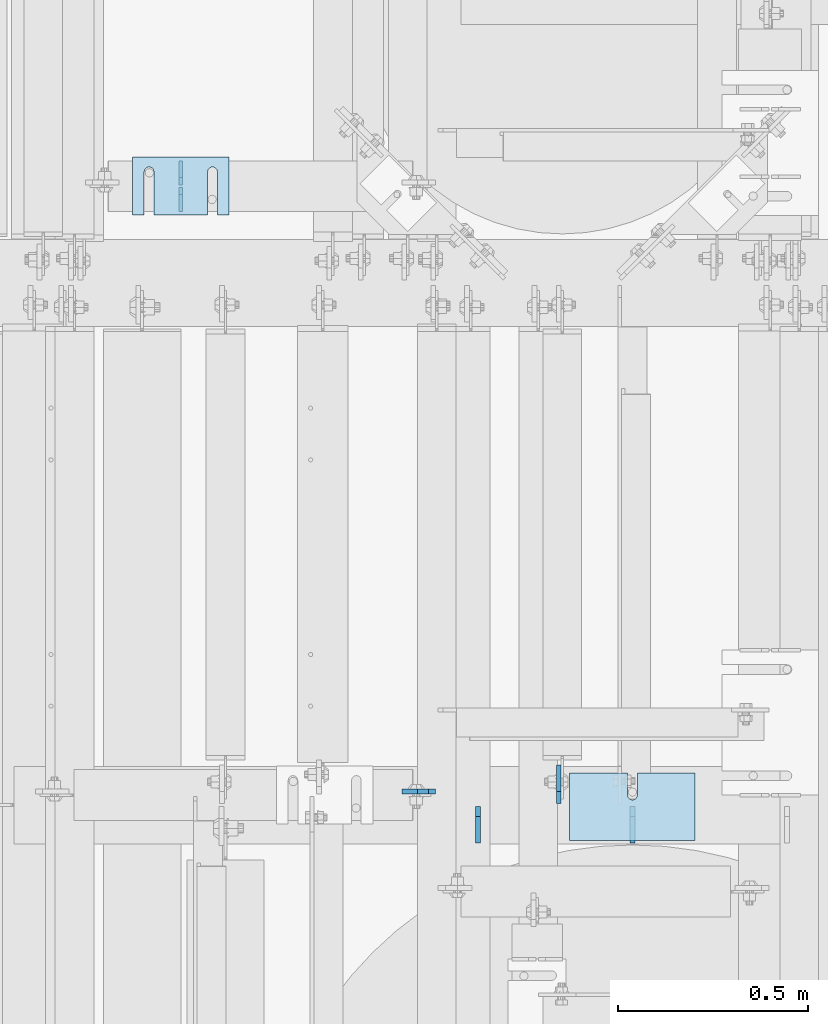
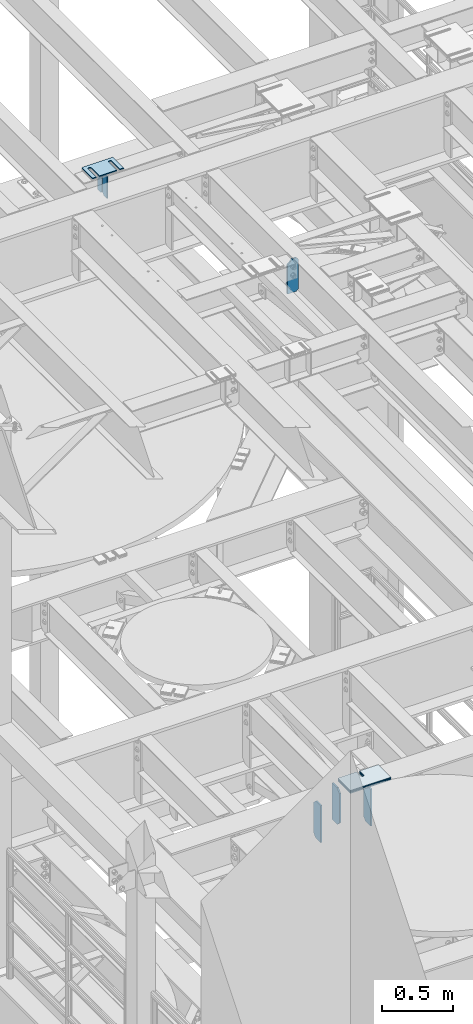
# One storey, part 1698 of 1876: 14 plates, 11 elements without a shape of their own.
"""IFC2X3 building model written with IfcOpenShell, lengths in millimetres."""

import ifcopenshell
import ifcopenshell.guid

model = None  # the IFC model being written
_history = None  # IfcOwnerHistory: only IFC2X3 demands one
_inside = {}  # id of a spatial element -> (the spatial element, [elements in it])
_under = {}  # id of a project, library or spatial element -> (it, [spatial elements below it])
_declared = {}  # id of a project -> (the project, [libraries it declares])
_typed = {}  # id of a type object -> (the type object, [elements of that type])
_made_of = {}  # id of a material, layer set ... -> (it, [elements and type objects made of it])


def new_model(schema):
    """Start an empty IFC model of exactly this schema.

    Asked for "IFC4X3", IfcOpenShell would pick the latest addendum, in which some entities
    have other attributes; the version numbers below select the first issue.
    IFC2X3 requires an IfcOwnerHistory on every rooted entity: one is made here for all.
    """
    global model, _history
    if schema == "IFC4X3":
        model = ifcopenshell.file(schema_version=(4, 3, 0, 0))
    else:
        model = ifcopenshell.file(schema=schema)
    _inside.clear()
    _under.clear()
    _declared.clear()
    _typed.clear()
    _made_of.clear()
    _history = None
    if model.schema == "IFC2X3":
        org = make("IfcOrganization", Name="unknown")
        user = make(
            "IfcPersonAndOrganization",
            ThePerson=make("IfcPerson", FamilyName="unknown"),
            TheOrganization=org,
        )
        app = make(
            "IfcApplication",
            ApplicationDeveloper=org,
            Version="unknown",
            ApplicationFullName="unknown",
            ApplicationIdentifier="unknown",
        )
        _history = make(
            "IfcOwnerHistory",
            OwningUser=user,
            OwningApplication=app,
            ChangeAction="ADDED",
            CreationDate=0,
        )
    return model


def make(cls, **values):
    """One entity of the class cls with the attributes given. An attribute that is None is left unset."""
    return model.create_entity(
        cls, **{name: value for name, value in values.items() if value is not None}
    )


def rooted(cls, **values):
    """An entity with a GlobalId (a new one), such as an element, a storey or a relation."""
    return make(cls, GlobalId=ifcopenshell.guid.new(), OwnerHistory=_history, **values)


def si_unit(unit_type, name, prefix=None):
    """IfcSIUnit, for example si_unit("LENGTHUNIT", "METRE", prefix="MILLI")."""
    return make("IfcSIUnit", UnitType=unit_type, Prefix=prefix, Name=name)


def assignment(units):
    """IfcUnitAssignment: the units of a project."""
    return None if units is None else make("IfcUnitAssignment", Units=units)


def point(xyz):
    """IfcCartesianPoint."""
    return None if xyz is None else make("IfcCartesianPoint", Coordinates=xyz)


def direction(xyz):
    """IfcDirection."""
    return None if xyz is None else make("IfcDirection", DirectionRatios=xyz)


def frame(location, z_axis=None, x_axis=None):
    """IfcAxis2Placement3D, a coordinate frame: its origin and axes. An axis left out is left unset."""
    return make(
        "IfcAxis2Placement3D",
        Location=point(location),
        Axis=direction(z_axis),
        RefDirection=direction(x_axis),
    )


def origin_with_axes():
    """The frame at (0, 0, 0) with the z axis (0, 0, 1) and the x axis (1, 0, 0) written out."""
    return frame((0.0, 0.0, 0.0), z_axis=(0.0, 0.0, 1.0), x_axis=(1.0, 0.0, 0.0))


def place(relative_to, where):
    """IfcLocalPlacement: puts the frame where relative to a parent placement (None: the world)."""
    return make(
        "IfcLocalPlacement", PlacementRelTo=relative_to, RelativePlacement=where
    )


def context(
    kind, dimensions, precision=None, world=None, true_north=None, identifier=None
):
    """IfcGeometricRepresentationContext, for example the 3D "Model" context."""
    return make(
        "IfcGeometricRepresentationContext",
        ContextIdentifier=identifier,
        ContextType=kind,
        CoordinateSpaceDimension=dimensions,
        Precision=precision,
        WorldCoordinateSystem=world,
        TrueNorth=true_north,
    )


def subcontext(parent, identifier, kind, view, scale=None):
    """IfcGeometricRepresentationSubContext, for example "Body" below "Model"."""
    return make(
        "IfcGeometricRepresentationSubContext",
        ContextIdentifier=identifier,
        ContextType=kind,
        ParentContext=parent,
        TargetScale=scale,
        TargetView=view,
    )


def project(units=None, contexts=None):
    """IfcProject with its units and contexts."""
    return rooted(
        "IfcProject",
        Name="project",
        RepresentationContexts=contexts,
        UnitsInContext=assignment(units),
    )


def spatial(cls, under=None, at=None, **own):
    """A site, building, storey or space (cls), placed at a placement, below another one or the project."""
    s = rooted(cls, ObjectPlacement=at, **own)
    if under is not None:
        _under.setdefault(under.id(), (under, []))[1].append(s)
    return s


def faces_of(points, faces, orient=None, outer=None):
    """IfcFace entities. A face is a list of loops; a loop is a list of indices into points, from 0.

    orient and outer hold one flag for each loop. By default every Orientation is true, the
    first loop of a face is its IfcFaceOuterBound and the others are IfcFaceBound.
    """
    made = []
    for i, loops in enumerate(faces):
        bounds = []
        for j, loop in enumerate(loops):
            is_outer = j == 0 if outer is None else outer[i][j]
            bounds.append(
                make(
                    "IfcFaceOuterBound" if is_outer else "IfcFaceBound",
                    Bound=make("IfcPolyLoop", Polygon=[points[k] for k in loop]),
                    Orientation=True if orient is None else orient[i][j],
                )
            )
        made.append(make("IfcFace", Bounds=bounds))
    return made


def faceted_brep(points, faces, orient=None, outer=None, voids=None):
    """IfcFacetedBrep: a solid bounded by flat faces; with voids (closed shells), ...WithVoids."""
    shared = [point(p) for p in points]
    hull = make("IfcClosedShell", CfsFaces=faces_of(shared, faces, orient, outer))
    if voids is None:
        return make("IfcFacetedBrep", Outer=hull)
    return make(
        "IfcFacetedBrepWithVoids",
        Outer=hull,
        Voids=[
            make(cls, CfsFaces=faces_of(shared, fs, o, b)) for cls, fs, o, b in voids
        ],
    )


def shape(context_of_items, identifier, shape_type, items):
    """IfcShapeRepresentation: the items that make up one representation, for example the "Body"."""
    return make(
        "IfcShapeRepresentation",
        ContextOfItems=context_of_items,
        RepresentationIdentifier=identifier,
        RepresentationType=shape_type,
        Items=items,
    )


def material(Name=None, Category=None):
    """IfcMaterial."""
    return make("IfcMaterial", Name=Name, Category=Category)


def made_of(thing, what):
    """Note that an element or type object is made of a material, layer set ...; save() writes the relation."""
    if what is not None:
        _made_of.setdefault(what.id(), (what, []))[1].append(thing)
    return thing


def type_object(cls, material=None, **own):
    """A type object (cls), such as IfcWallType, which elements share."""
    return made_of(rooted(cls, **own), material)


def element(
    cls,
    number,
    at=None,
    inside=None,
    cuts=None,
    type_object=None,
    material=None,
    context=None,
    identifier="Body",
    shape_type=None,
    held_by="IfcProductDefinitionShape",
    body=None,
    shapes=None,
    **own,
):
    """One element of the class cls, such as IfcWall. Its Tag is "e" and its number.

    at: its placement. inside: the storey or other place that contains it. cuts: it is an
    opening in that element (IfcRelVoidsElement). A single representation is given by context,
    identifier, shape_type and body (its items); several are given by shapes. held_by: the class
    of the entity that holds the representations. save() writes the other relations.
    """
    e = rooted(cls, Tag="e%d" % number, ObjectPlacement=at, **own)
    if body is not None:
        shapes = [shape(context, identifier, shape_type, body)]
    if shapes is not None:
        e.Representation = make(held_by, Representations=shapes)
    if inside is not None:
        _inside.setdefault(inside.id(), (inside, []))[1].append(e)
    if cuts is not None:
        rooted(
            "IfcRelVoidsElement", RelatingBuildingElement=cuts, RelatedOpeningElement=e
        )
    if type_object is not None:
        _typed.setdefault(type_object.id(), (type_object, []))[1].append(e)
    return made_of(e, material)


def aggregate(whole, parts):
    """IfcRelAggregates: a whole, such as a stair, and the parts it consists of."""
    return rooted("IfcRelAggregates", RelatingObject=whole, RelatedObjects=parts)


def save(model, path):
    """Write the relations noted so far, then the file.

    IfcRelAggregates (storeys below a building ...), IfcRelContainedInSpatialStructure (elements
    in a storey), IfcRelDefinesByType, IfcRelAssociatesMaterial and IfcRelDeclares: one each for
    every whole, place, type object, material and project.
    """
    for whole, parts in _under.values():
        aggregate(whole, parts)
    for where, things in _inside.values():
        rooted(
            "IfcRelContainedInSpatialStructure",
            RelatedElements=things,
            RelatingStructure=where,
        )
    for kind, things in _typed.values():
        rooted("IfcRelDefinesByType", RelatedObjects=things, RelatingType=kind)
    for what, things in _made_of.values():
        rooted("IfcRelAssociatesMaterial", RelatedObjects=things, RelatingMaterial=what)
    for by, libraries in _declared.values():
        rooted("IfcRelDeclares", RelatingContext=by, RelatedDefinitions=libraries)
    model.write(path)


model = new_model("IFC2X3")

# Units and contexts
model_context = context("Model", 3, precision=1e-05, world=origin_with_axes())
body_context = subcontext(model_context, "Body", "Model", "MODEL_VIEW")
ifc_project = project(units=[si_unit("LENGTHUNIT", "METRE", prefix="MILLI"), si_unit("AREAUNIT", "SQUARE_METRE"), si_unit("VOLUMEUNIT", "CUBIC_METRE"), si_unit("MASSUNIT", "GRAM", prefix="KILO"), si_unit("TIMEUNIT", "SECOND"), si_unit("PLANEANGLEUNIT", "RADIAN"), si_unit("SOLIDANGLEUNIT", "STERADIAN"), si_unit("THERMODYNAMICTEMPERATUREUNIT", "DEGREE_CELSIUS"), si_unit("LUMINOUSINTENSITYUNIT", "LUMEN")], contexts=[model_context])

# Site, building, storey
site_placement = place(None, origin_with_axes())
site = spatial("IfcSite", under=ifc_project, at=site_placement, CompositionType="ELEMENT")
building_placement = place(site_placement, origin_with_axes())
building = spatial("IfcBuilding", under=site, at=building_placement, Name="Undefined", CompositionType="ELEMENT")
storey_placement = place(building_placement, origin_with_axes())
storey = spatial("IfcBuildingStorey", under=building, at=storey_placement, Name="Undefined", CompositionType="ELEMENT", Elevation=0.0)

# Assembly, plates
assembly_1_placement = place(storey_placement, origin_with_axes())
assembly_1 = element("IfcElementAssembly", 1, at=assembly_1_placement, inside=storey, Name="BEAM", AssemblyPlace="NOTDEFINED", PredefinedType="RIGID_FRAME")
ifc_material = material(Name="STEEL/A36")
plate_type_1 = type_object("IfcPlateType", PredefinedType="NOTDEFINED")
plate_1_placement = place(assembly_1_placement, frame((2184.3990270089, 7807.49544067383, 17784.7625), z_axis=(0.0, 0.0, 1.0), x_axis=(0.0, 1.0, 0.0)))
plate_1 = element("IfcPlate", 2, at=plate_1_placement, type_object=plate_type_1, material=ifc_material, Name="PLATE", context=body_context, shape_type="Brep", body=[
    faceted_brep([(0.0, -4.76249999999982, 0.0), (0.0, -4.76249999999982, 190.5), (0.0, 4.76249999999982, 190.5), (0.0, 4.76249999999982, 0.0), (44.4500007629395, -4.76249999999982, 190.5), (44.4500007629395, 4.76249999999982, 190.5), (63.5, -4.76249999999982, 171.450000762939), (63.5, 4.76249999999982, 171.450000762939), (63.5, -4.76249999999982, 19.0499992370605), (63.5, 4.76249999999982, 19.0499992370605), (44.4500007629395, -4.76249999999982, 0.0), (44.4500007629395, 4.76249999999982, 0.0)], [[[0, 1, 2, 3]], [[1, 4, 5, 2]], [[4, 6, 7, 5]], [[6, 8, 9, 7]], [[8, 10, 11, 9]], [[10, 0, 3, 11]], [[5, 7, 9, 11, 3, 2]], [[10, 8, 6, 4, 1, 0]]]),
])
plate_2_placement = place(assembly_1_placement, frame((2184.3990270089, 7877.34544067383, 17784.7625), z_axis=(0.0, 0.0, 1.0), x_axis=(0.0, 1.0, 0.0)))
plate_2 = element("IfcPlate", 3, at=plate_2_placement, type_object=plate_type_1, material=ifc_material, Name="PLATE", context=body_context, shape_type="Brep", body=[
    faceted_brep([(0.0, -4.76249999999982, 19.0499992370605), (0.0, -4.76249999999982, 171.450000762939), (0.0, 4.76249999999982, 171.450000762939), (0.0, 4.76249999999982, 19.0499992370605), (19.0499992370605, -4.76249999999982, 190.5), (19.0499992370605, 4.76249999999982, 190.5), (63.5, -4.76249999999982, 190.5), (63.5, 4.76249999999982, 190.5), (63.5, -4.76249999999982, 0.0), (63.5, 4.76249999999982, 0.0), (19.0499992370605, -4.76249999999982, 0.0), (19.0499992370605, 4.76249999999982, 0.0)], [[[0, 1, 2, 3]], [[1, 4, 5, 2]], [[4, 6, 7, 5]], [[6, 8, 9, 7]], [[8, 10, 11, 9]], [[10, 0, 3, 11]], [[5, 7, 9, 11, 3, 2]], [[10, 8, 6, 4, 1, 0]]]),
])
aggregate(assembly_1, [plate_1, plate_2])

# Assembly, plate
assembly_2_placement = place(storey_placement, origin_with_axes())
assembly_2 = element("IfcElementAssembly", 4, at=assembly_2_placement, inside=storey, Name="BEAM", AssemblyPlace="NOTDEFINED", PredefinedType="RIGID_FRAME")
plate_type_2 = type_object("IfcPlateType", PredefinedType="NOTDEFINED")
plate_3_placement = place(assembly_2_placement, frame((2854.325, 6282.7016907692, 17686.3375), z_axis=(0.0, 0.0, 1.0), x_axis=(-1.0, 0.0, 0.0)))
plate_3 = element("IfcPlate", 5, at=plate_3_placement, type_object=plate_type_2, material=ifc_material, Name="PLATE", context=body_context, shape_type="Brep", body=[
    faceted_brep([(0.0, -6.35000000000036, 271.462512969971), (19.0499992370605, -6.35000000000036, 290.512512207031), (19.0499992370605, 6.35000000000036, 290.512512207031), (0.0, 6.35000000000036, 271.462512969971), (0.0, -6.35000000000196, 19.0499992370605), (0.0, 6.35000000000105, 19.0499992370605), (19.0499992370642, -6.35000000000105, 0.0), (19.0499992370633, 6.35000000000105, 0.0), (88.9000015258789, -6.34999999999991, 0.0), (88.9000015258789, 6.34999999999991, 0.0), (88.9000015258789, -6.35000000000036, 249.323622869222), (47.7109133477634, -6.35000000000036, 290.512512207031), (47.6728323916896, 6.35000000000036, 290.512512207031), (88.9000015258789, 6.35000000000036, 249.285542096986)], [[[0, 1, 2, 3]], [[4, 0, 3, 5]], [[6, 4, 5, 7]], [[8, 6, 7, 9]], [[1, 0, 4, 6, 8, 10, 11]], [[2, 1, 11, 12]], [[9, 7, 5, 3, 2, 12, 13]], [[8, 9, 13, 10]], [[12, 11, 10, 13]]]),
])
aggregate(assembly_2, [plate_3])

# Assembly, plates
assembly_3_placement = place(storey_placement, origin_with_axes())
assembly_3 = element("IfcElementAssembly", 6, at=assembly_3_placement, inside=storey, Name="BEAM", AssemblyPlace="NOTDEFINED", PredefinedType="RIGID_FRAME")
plate_type_3 = type_object("IfcPlateType", PredefinedType="NOTDEFINED")
plate_4_placement = place(assembly_3_placement, frame((3371.85, 6147.59375, 12976.225), z_axis=(0.0, 0.0, 1.0), x_axis=(0.0, 1.0, 0.0)))
plate_4 = element("IfcPlate", 7, at=plate_4_placement, type_object=plate_type_3, material=ifc_material, Name="PLATE", context=body_context, shape_type="Brep", body=[
    faceted_brep([(0.0, -6.35000000000036, 0.0), (1.81898940354586e-12, -6.35000000000127, 317.5), (0.0, 6.35000000000036, 317.5), (0.0, 6.35000000000036, 0.0), (69.8500003814697, -6.34999999999991, 317.5), (69.8500003814697, 6.34999999999991, 317.5), (95.25, -6.34999999999991, 292.10000038147), (95.25, 6.34999999999991, 292.10000038147), (95.25, -6.34999999999991, 25.3999996185303), (95.25, 6.34999999999991, 25.3999996185303), (69.8500003814697, -6.34999999999991, 0.0), (69.8500003814697, 6.34999999999991, 0.0)], [[[0, 1, 2, 3]], [[1, 4, 5, 2]], [[4, 6, 7, 5]], [[6, 8, 9, 7]], [[8, 10, 11, 9]], [[10, 0, 3, 11]], [[5, 7, 9, 11, 3, 2]], [[10, 8, 6, 4, 1, 0]]]),
])
plate_5_placement = place(assembly_3_placement, frame((2965.4499996825, 6147.59375, 12976.225), z_axis=(0.0, 0.0, 1.0), x_axis=(0.0, 1.0, 0.0)))
plate_5 = element("IfcPlate", 8, at=plate_5_placement, type_object=plate_type_3, material=ifc_material, Name="PLATE", context=body_context, shape_type="Brep", body=[
    faceted_brep([(0.0, -6.35000000000036, 0.0), (1.81898940354586e-12, -6.35000000000127, 317.5), (0.0, 6.35000000000036, 317.5), (0.0, 6.35000000000036, 0.0), (69.8500003814697, -6.34999999999991, 317.5), (69.8500003814697, 6.34999999999991, 317.5), (95.25, -6.34999999999991, 292.10000038147), (95.25, 6.34999999999991, 292.10000038147), (95.25, -6.34999999999991, 25.3999996185303), (95.25, 6.34999999999991, 25.3999996185303), (69.8500003814697, -6.34999999999991, 0.0), (69.8500003814697, 6.34999999999991, 0.0)], [[[0, 1, 2, 3]], [[1, 4, 5, 2]], [[4, 6, 7, 5]], [[6, 8, 9, 7]], [[8, 10, 11, 9]], [[10, 0, 3, 11]], [[5, 7, 9, 11, 3, 2]], [[10, 8, 6, 4, 1, 0]]]),
])
plate_type_4 = type_object("IfcPlateType", PredefinedType="NOTDEFINED")
plate_6_placement = place(assembly_3_placement, frame((3178.17499990463, 6250.78125, 12977.8125), z_axis=(0.0, 0.0, 1.0), x_axis=(0.0, 1.0, 0.0)))
plate_6 = element("IfcPlate", 9, at=plate_6_placement, type_object=plate_type_4, material=ifc_material, Name="PLATE", context=body_context, shape_type="Brep", body=[
    faceted_brep([(0.0, -6.34999999999991, 31.75), (-1.81898940354586e-12, -6.34999999999991, 284.162506103516), (1.81898940354586e-12, 6.35000000000173, 284.162506103516), (0.0, 6.34999999999991, 31.75), (31.7499999999927, -6.34999999999991, 315.912506103516), (31.7499999999982, 6.35000000000309, 315.912506103516), (101.599998474121, -6.35000000000036, 315.912506103516), (101.599998474121, 6.35000000000036, 315.912506103516), (101.599998474121, -6.35000000000036, 0.0), (101.599998474121, 6.35000000000036, 0.0), (31.75, -6.34999999999991, 0.0), (31.75, 6.34999999999991, 0.0)], [[[0, 1, 2, 3]], [[1, 4, 5, 2]], [[4, 6, 7, 5]], [[6, 8, 9, 7]], [[8, 10, 11, 9]], [[10, 0, 3, 11]], [[5, 7, 9, 11, 3, 2]], [[10, 8, 6, 4, 1, 0]]]),
])
aggregate(assembly_3, [plate_4, plate_5, plate_6])

# Assembly, plate
assembly_4_placement = place(storey_placement, origin_with_axes())
assembly_4 = element("IfcElementAssembly", 10, at=assembly_4_placement, inside=storey, Name="SHIM PLATE", AssemblyPlace="NOTDEFINED", PredefinedType="RIGID_FRAME")
plate_type_5 = type_object("IfcPlateType", PredefinedType="NOTDEFINED")
plate_7_placement = place(assembly_4_placement, frame((2311.39928127175, 7950.43846988776, 18009.3925), z_axis=(0.0, -1.0, 0.0), x_axis=(-1.0, 0.0, 0.0)))
plate_7 = element("IfcPlate", 11, at=plate_7_placement, type_object=plate_type_5, material=ifc_material, Name="SHIM PLATE", context=body_context, shape_type="Brep", body=[
    faceted_brep([(30.8791924037423, -0.793499999999767, 152.398895263674), (30.8814140421409, -0.793499999999767, 38.0994505407325), (30.8814140421409, 0.793499999999767, 38.0994505407325), (30.8791924037423, 0.793499999999767, 152.398895263674), (32.5828868936751, -0.793499999999767, 31.7494480341243), (32.5828868936751, 0.793499999999767, 31.7494480341243), (37.2314075583954, -0.793499999999767, 27.1009216732054), (37.2314075583954, 0.793499999999767, 27.1009216732054), (43.5814079800521, -0.793499999999767, 25.3994410405157), (43.5814079800521, 0.793499999999767, 25.3994410405157), (49.9314097200559, -0.793499999999767, 27.1009167530574), (49.9314097200559, 0.793499999999767, 27.1009167530574), (54.5799339865616, -0.793499999999767, 31.7494395121785), (54.5799339865616, 0.793499999999767, 31.7494395121785), (56.2814117582284, -0.793499999999767, 38.0994407004391), (56.2814117582284, 0.793499999999767, 38.0994407004391), (56.2791901197206, -0.793499999999767, 152.398894414155), (56.2791901197206, 0.793499999999767, 152.398895263676), (9.09494701772928e-13, -0.793499999999767, 0.0), (1.98268335225293e-05, -0.793499999999767, 152.398895263672), (1.98268335225293e-05, 0.793499999999767, 152.398895263672), (9.09494701772928e-13, 0.793499999999767, 0.0), (253.999542236328, -0.793499999999767, 6.16182660451159e-11), (253.999542236328, 0.793499999999767, 6.16182660451159e-11), (253.999557495107, -0.793499999999767, 152.398895263688), (253.999557495107, 0.793499999999767, 152.398895263688), (223.116882380463, 0.793499999999767, 152.398895263686), (223.116882380463, -0.793499999999767, 152.398895415181), (223.119104018971, 0.793499999999767, 38.0994417014649), (223.119104018971, -0.793499999999767, 38.0994417014649), (221.417626247304, 0.793499999999767, 31.7494405132047), (221.417626247304, -0.793499999999767, 31.7494405132047), (216.769101980798, 0.793499999999767, 27.1009177540836), (216.769101980798, -0.793499999999767, 27.1009177540836), (210.419100240794, 0.793499999999767, 25.399442041542), (210.419100240794, -0.793499999999767, 25.399442041542), (204.069099819138, 0.793499999999767, 27.1009226742317), (204.069099819138, -0.793499999999767, 27.1009226742317), (199.420579154417, 0.793499999999767, 31.7494490351505), (199.420579154417, -0.793499999999767, 31.7494490351505), (197.719106302883, 0.793499999999767, 38.0994515417583), (197.719106302883, -0.793499999999767, 38.0994515417583), (197.716884664484, -0.793499999999767, 152.398895263684), (197.716884664484, 0.793499999999767, 152.398895263684)], [[[0, 1, 2, 3]], [[4, 5, 2, 1]], [[6, 7, 5, 4]], [[8, 9, 7, 6]], [[10, 11, 9, 8]], [[12, 13, 11, 10]], [[14, 15, 13, 12]], [[16, 17, 15, 14]], [[18, 19, 20, 21]], [[22, 18, 21, 23]], [[24, 22, 23, 25]], [[24, 25, 26, 27]], [[27, 26, 28, 29]], [[29, 28, 30, 31]], [[31, 30, 32, 33]], [[33, 32, 34, 35]], [[35, 34, 36, 37]], [[37, 36, 38, 39]], [[39, 38, 40, 41]], [[42, 41, 40, 43]], [[12, 10, 8, 6, 4, 1, 0, 19, 18, 22, 24, 27, 29, 31, 33, 35, 37, 39, 41, 42, 16, 14]], [[20, 19, 0, 3]], [[43, 40, 38, 36, 34, 32, 30, 28, 26, 25, 23, 21, 20, 3, 2, 5, 7, 9, 11, 13, 15, 17]], [[42, 43, 17, 16]]]),
])
aggregate(assembly_4, [plate_7])

assembly_5_placement = place(storey_placement, origin_with_axes())
assembly_5 = element("IfcElementAssembly", 12, at=assembly_5_placement, inside=storey, Name="SHIM PLATE", AssemblyPlace="NOTDEFINED", PredefinedType="RIGID_FRAME")
plate_type_6 = type_object("IfcPlateType", PredefinedType="NOTDEFINED")
plate_8_placement = place(assembly_5_placement, frame((2311.39928127175, 7950.43846988799, 18007.0115), z_axis=(0.0, -1.0, 0.0), x_axis=(-1.0, 0.0, 0.0)))
plate_8 = element("IfcPlate", 13, at=plate_8_placement, type_object=plate_type_6, material=ifc_material, Name="SHIM PLATE", context=body_context, shape_type="Brep", body=[
    faceted_brep([(30.8791924037423, -1.58750000000146, 152.398895263674), (30.8814140421409, -1.58750000000146, 38.0994505407325), (30.8814140421409, 1.58750000000146, 38.0994505407325), (30.8791924037423, 1.58750000000146, 152.398895263674), (32.5828868936751, -1.58750000000146, 31.7494480341243), (32.5828868936751, 1.58750000000146, 31.7494480341243), (37.2314075583954, -1.58750000000146, 27.1009216732054), (37.2314075583954, 1.58750000000146, 27.1009216732054), (43.5814079800521, -1.58750000000146, 25.3994410405157), (43.5814079800521, 1.58750000000146, 25.3994410405157), (49.9314097200559, -1.58750000000146, 27.1009167530574), (49.9314097200559, 1.58750000000146, 27.1009167530574), (54.5799339865616, -1.58750000000146, 31.7494395121785), (54.5799339865616, 1.58750000000146, 31.7494395121785), (56.2814117582284, -1.58750000000146, 38.0994407004391), (56.2814117582284, 1.58750000000146, 38.0994407004391), (56.2791901197206, -1.58750000000146, 152.398894414155), (56.2791901197206, 1.58750000000146, 152.398895263676), (9.09494701772928e-13, -1.58750000000146, 4.54747350886464e-13), (1.98264133359771e-05, -1.58750000000146, 152.398895263672), (1.98264133359771e-05, 1.58750000000146, 152.398895263672), (9.09494701772928e-13, 1.58750000000146, 4.54747350886464e-13), (253.999542236328, -1.58750000000146, 6.16182660451159e-11), (253.999542236328, 1.58750000000146, 6.16182660451159e-11), (253.999557495107, -1.58750000000146, 152.398895263688), (253.999557495107, 1.58750000000146, 152.398895263688), (223.116882380463, 1.58750000000146, 152.398895263686), (223.116882380463, -1.58750000000146, 152.398895415181), (223.119104018971, 1.58750000000146, 38.0994417014649), (223.119104018971, -1.58750000000146, 38.0994417014649), (221.417626247304, 1.58750000000146, 31.7494405132047), (221.417626247304, -1.58750000000146, 31.7494405132047), (216.769101980798, 1.58750000000146, 27.1009177540836), (216.769101980798, -1.58750000000146, 27.1009177540836), (210.419100240794, 1.58750000000146, 25.399442041542), (210.419100240794, -1.58750000000146, 25.399442041542), (204.069099819138, 1.58750000000146, 27.1009226742317), (204.069099819138, -1.58750000000146, 27.1009226742317), (199.420579154417, 1.58750000000146, 31.7494490351505), (199.420579154417, -1.58750000000146, 31.7494490351505), (197.719106302883, 1.58750000000146, 38.0994515417583), (197.719106302883, -1.58750000000146, 38.0994515417583), (197.716884664484, -1.58750000000146, 152.398895263684), (197.716884664484, 1.58750000000146, 152.398895263684)], [[[0, 1, 2, 3]], [[4, 5, 2, 1]], [[6, 7, 5, 4]], [[8, 9, 7, 6]], [[10, 11, 9, 8]], [[12, 13, 11, 10]], [[14, 15, 13, 12]], [[16, 17, 15, 14]], [[18, 19, 20, 21]], [[22, 18, 21, 23]], [[24, 22, 23, 25]], [[24, 25, 26, 27]], [[27, 26, 28, 29]], [[29, 28, 30, 31]], [[31, 30, 32, 33]], [[33, 32, 34, 35]], [[35, 34, 36, 37]], [[37, 36, 38, 39]], [[39, 38, 40, 41]], [[42, 41, 40, 43]], [[12, 10, 8, 6, 4, 1, 0, 19, 18, 22, 24, 27, 29, 31, 33, 35, 37, 39, 41, 42, 16, 14]], [[20, 19, 0, 3]], [[43, 40, 38, 36, 34, 32, 30, 28, 26, 25, 23, 21, 20, 3, 2, 5, 7, 9, 11, 13, 15, 17]], [[42, 43, 17, 16]]]),
])
aggregate(assembly_5, [plate_8])

assembly_6_placement = place(storey_placement, origin_with_axes())
assembly_6 = element("IfcElementAssembly", 14, at=assembly_6_placement, inside=storey, Name="SHIM PLATE", AssemblyPlace="NOTDEFINED", PredefinedType="RIGID_FRAME")
plate_9_placement = place(assembly_6_placement, frame((2311.39928127175, 7950.43846988822, 18003.8365), z_axis=(0.0, -1.0, 0.0), x_axis=(-1.0, 0.0, 0.0)))
plate_9 = element("IfcPlate", 15, at=plate_9_placement, type_object=plate_type_6, material=ifc_material, Name="SHIM PLATE", context=body_context, shape_type="Brep", body=[
    faceted_brep([(30.8791924037423, -1.58750000000146, 152.398895263674), (30.8814140421409, -1.58750000000146, 38.0994505407325), (30.8814140421409, 1.58750000000146, 38.0994505407325), (30.8791924037423, 1.58750000000146, 152.398895263674), (32.5828868936751, -1.58750000000146, 31.7494480341243), (32.5828868936751, 1.58750000000146, 31.7494480341243), (37.2314075583954, -1.58750000000146, 27.1009216732054), (37.2314075583954, 1.58750000000146, 27.1009216732054), (43.5814079800521, -1.58750000000146, 25.3994410405157), (43.5814079800521, 1.58750000000146, 25.3994410405157), (49.9314097200559, -1.58750000000146, 27.1009167530574), (49.9314097200559, 1.58750000000146, 27.1009167530574), (54.5799339865616, -1.58750000000146, 31.7494395121785), (54.5799339865616, 1.58750000000146, 31.7494395121785), (56.2814117582284, -1.58750000000146, 38.0994407004391), (56.2814117582284, 1.58750000000146, 38.0994407004391), (56.2791901197206, -1.58750000000146, 152.398894414155), (56.2791901197206, 1.58750000000146, 152.398895263676), (9.09494701772928e-13, -1.58750000000146, 4.54747350886464e-13), (1.98264133359771e-05, -1.58750000000146, 152.398895263672), (1.98264133359771e-05, 1.58750000000146, 152.398895263672), (9.09494701772928e-13, 1.58750000000146, 4.54747350886464e-13), (253.999542236328, -1.58750000000146, 6.16182660451159e-11), (253.999542236328, 1.58750000000146, 6.16182660451159e-11), (253.999557495107, -1.58750000000146, 152.398895263688), (253.999557495107, 1.58750000000146, 152.398895263688), (223.116882380463, 1.58750000000146, 152.398895263686), (223.116882380463, -1.58750000000146, 152.398895415181), (223.119104018971, 1.58750000000146, 38.0994417014649), (223.119104018971, -1.58750000000146, 38.0994417014649), (221.417626247304, 1.58750000000146, 31.7494405132047), (221.417626247304, -1.58750000000146, 31.7494405132047), (216.769101980798, 1.58750000000146, 27.1009177540836), (216.769101980798, -1.58750000000146, 27.1009177540836), (210.419100240794, 1.58750000000146, 25.399442041542), (210.419100240794, -1.58750000000146, 25.399442041542), (204.069099819138, 1.58750000000146, 27.1009226742317), (204.069099819138, -1.58750000000146, 27.1009226742317), (199.420579154417, 1.58750000000146, 31.7494490351505), (199.420579154417, -1.58750000000146, 31.7494490351505), (197.719106302883, 1.58750000000146, 38.0994515417583), (197.719106302883, -1.58750000000146, 38.0994515417583), (197.716884664484, -1.58750000000146, 152.398895263684), (197.716884664484, 1.58750000000146, 152.398895263684)], [[[0, 1, 2, 3]], [[4, 5, 2, 1]], [[6, 7, 5, 4]], [[8, 9, 7, 6]], [[10, 11, 9, 8]], [[12, 13, 11, 10]], [[14, 15, 13, 12]], [[16, 17, 15, 14]], [[18, 19, 20, 21]], [[22, 18, 21, 23]], [[24, 22, 23, 25]], [[24, 25, 26, 27]], [[27, 26, 28, 29]], [[29, 28, 30, 31]], [[31, 30, 32, 33]], [[33, 32, 34, 35]], [[35, 34, 36, 37]], [[37, 36, 38, 39]], [[39, 38, 40, 41]], [[42, 41, 40, 43]], [[12, 10, 8, 6, 4, 1, 0, 19, 18, 22, 24, 27, 29, 31, 33, 35, 37, 39, 41, 42, 16, 14]], [[20, 19, 0, 3]], [[43, 40, 38, 36, 34, 32, 30, 28, 26, 25, 23, 21, 20, 3, 2, 5, 7, 9, 11, 13, 15, 17]], [[42, 43, 17, 16]]]),
])
aggregate(assembly_6, [plate_9])

assembly_7_placement = place(storey_placement, origin_with_axes())
assembly_7 = element("IfcElementAssembly", 16, at=assembly_7_placement, inside=storey, Name="SHIM PLATE", AssemblyPlace="NOTDEFINED", PredefinedType="RIGID_FRAME")
plate_type_7 = type_object("IfcPlateType", PredefinedType="NOTDEFINED")
plate_10_placement = place(assembly_7_placement, frame((3205.99836578369, 6154.04776696703, 13333.4115), z_axis=(1.0, 0.0, 0.0), x_axis=(0.0, 1.0, 0.0)))
plate_10 = element("IfcPlate", 17, at=plate_10_placement, type_object=plate_type_7, material=ifc_material, Name="SHIM PLATE", context=body_context, shape_type="Brep", body=[
    faceted_brep([(177.654449462891, -1.58749999999964, 153.152024232435), (177.654449462891, 1.58749999999964, 153.152024232435), (118.915740966797, 1.58749999999964, 153.152024232435), (118.915740966797, -1.58749999999964, 153.152024232435), (112.565739046814, 1.58749999999964, 154.853499989362), (112.565739046814, -1.58749999999964, 154.853499989362), (107.917214530273, 1.58749999999964, 159.502022760557), (107.917214530273, -1.58749999999964, 159.502022760557), (106.21573638916, 1.58749999999964, 165.8520240417), (106.21573638916, -1.58749999999964, 165.8520240417), (107.917214530273, 1.58749999999964, 172.202025322844), (107.917214530273, -1.58749999999964, 172.202025322844), (112.565739046813, 1.58749999999964, 176.850548094039), (112.565739046813, -1.58749999999964, 176.850548094039), (118.915740966797, 1.58749999999964, 178.552023850965), (118.915740966797, -1.58749999999964, 178.552023850965), (177.654449462891, -1.58749999999964, 178.552023850965), (177.654449462891, 1.58749999999964, 178.552023850965), (177.654449462891, -1.58749999999964, 0.0), (9.09494701772928e-13, -1.58750000000146, 4.54747350886464e-13), (9.09494701772928e-13, 1.58750000000146, 4.54747350886464e-13), (177.654449462891, 1.58749999999964, 0.0), (0.0, -1.58749999999964, 330.201965332031), (0.0, 1.58749999999964, 330.201965332031), (177.654449462891, -1.58749999999964, 330.201965332031), (177.654449462891, 1.58749999999964, 330.201965332031)], [[[0, 1, 2, 3]], [[3, 2, 4, 5]], [[5, 4, 6, 7]], [[7, 6, 8, 9]], [[9, 8, 10, 11]], [[11, 10, 12, 13]], [[13, 12, 14, 15]], [[16, 15, 14, 17]], [[18, 19, 20, 21]], [[19, 22, 23, 20]], [[22, 24, 25, 23]], [[25, 24, 16, 17]], [[12, 10, 8, 6, 4, 2, 1, 21, 20, 23, 25, 17, 14]], [[18, 21, 1, 0]], [[24, 22, 19, 18, 0, 3, 5, 7, 9, 11, 13, 15, 16]]]),
])
aggregate(assembly_7, [plate_10])

assembly_8_placement = place(storey_placement, origin_with_axes())
assembly_8 = element("IfcElementAssembly", 18, at=assembly_8_placement, inside=storey, Name="SHIM PLATE", AssemblyPlace="NOTDEFINED", PredefinedType="RIGID_FRAME")
plate_11_placement = place(assembly_8_placement, frame((3205.99836578369, 6154.04776696703, 13330.2365), z_axis=(1.0, 0.0, 0.0), x_axis=(0.0, 1.0, 0.0)))
plate_11 = element("IfcPlate", 19, at=plate_11_placement, type_object=plate_type_7, material=ifc_material, Name="SHIM PLATE", context=body_context, shape_type="Brep", body=[
    faceted_brep([(177.654449462891, -1.58749999999964, 153.152024232435), (177.654449462891, 1.58749999999964, 153.152024232435), (118.915740966797, 1.58749999999964, 153.152024232435), (118.915740966797, -1.58749999999964, 153.152024232435), (112.565739046814, 1.58749999999964, 154.853499989362), (112.565739046814, -1.58749999999964, 154.853499989362), (107.917214530273, 1.58749999999964, 159.502022760557), (107.917214530273, -1.58749999999964, 159.502022760557), (106.21573638916, 1.58749999999964, 165.8520240417), (106.21573638916, -1.58749999999964, 165.8520240417), (107.917214530273, 1.58749999999964, 172.202025322844), (107.917214530273, -1.58749999999964, 172.202025322844), (112.565739046813, 1.58749999999964, 176.850548094039), (112.565739046813, -1.58749999999964, 176.850548094039), (118.915740966797, 1.58749999999964, 178.552023850965), (118.915740966797, -1.58749999999964, 178.552023850965), (177.654449462891, -1.58749999999964, 178.552023850965), (177.654449462891, 1.58749999999964, 178.552023850965), (177.654449462891, -1.58749999999964, 0.0), (9.09494701772928e-13, -1.58750000000146, 4.54747350886464e-13), (9.09494701772928e-13, 1.58750000000146, 4.54747350886464e-13), (177.654449462891, 1.58749999999964, 0.0), (0.0, -1.58749999999964, 330.201965332031), (0.0, 1.58749999999964, 330.201965332031), (177.654449462891, -1.58749999999964, 330.201965332031), (177.654449462891, 1.58749999999964, 330.201965332031)], [[[0, 1, 2, 3]], [[3, 2, 4, 5]], [[5, 4, 6, 7]], [[7, 6, 8, 9]], [[9, 8, 10, 11]], [[11, 10, 12, 13]], [[13, 12, 14, 15]], [[16, 15, 14, 17]], [[18, 19, 20, 21]], [[19, 22, 23, 20]], [[22, 24, 25, 23]], [[25, 24, 16, 17]], [[12, 10, 8, 6, 4, 2, 1, 21, 20, 23, 25, 17, 14]], [[18, 21, 1, 0]], [[24, 22, 19, 18, 0, 3, 5, 7, 9, 11, 13, 15, 16]]]),
])
aggregate(assembly_8, [plate_11])

assembly_9_placement = place(storey_placement, origin_with_axes())
assembly_9 = element("IfcElementAssembly", 20, at=assembly_9_placement, inside=storey, Name="SHIM PLATE", AssemblyPlace="NOTDEFINED", PredefinedType="RIGID_FRAME")
plate_type_8 = type_object("IfcPlateType", PredefinedType="NOTDEFINED")
plate_12_placement = place(assembly_9_placement, frame((3205.99836578369, 6154.04776696703, 13326.268), z_axis=(1.0, 0.0, 0.0), x_axis=(0.0, 1.0, 0.0)))
plate_12 = element("IfcPlate", 21, at=plate_12_placement, type_object=plate_type_8, material=ifc_material, Name="SHIM PLATE", context=body_context, shape_type="Brep", body=[
    faceted_brep([(177.654449462891, -2.3809999999994, 153.152024232435), (177.654449462891, 2.3809999999994, 153.152024232435), (118.915740966797, 2.3809999999994, 153.152024232435), (118.915740966797, -2.3809999999994, 153.152024232435), (112.565739046814, 2.3809999999994, 154.853499989362), (112.565739046814, -2.3809999999994, 154.853499989362), (107.917214530273, 2.3809999999994, 159.502022760557), (107.917214530273, -2.3809999999994, 159.502022760557), (106.21573638916, 2.3809999999994, 165.8520240417), (106.21573638916, -2.3809999999994, 165.8520240417), (107.917214530273, 2.3809999999994, 172.202025322844), (107.917214530273, -2.3809999999994, 172.202025322844), (112.565739046813, 2.3809999999994, 176.850548094039), (112.565739046813, -2.3809999999994, 176.850548094039), (118.915740966797, 2.3809999999994, 178.552023850965), (118.915740966797, -2.3809999999994, 178.552023850965), (177.654449462891, -2.3809999999994, 178.552023850965), (177.654449462891, 2.3809999999994, 178.552023850965), (177.654449462891, -2.3809999999994, 0.0), (0.0, -2.38100000000122, 4.54747350886464e-13), (0.0, 2.38100000000122, 4.54747350886464e-13), (177.654449462891, 2.3809999999994, 0.0), (0.0, -2.3809999999994, 330.201965332031), (0.0, 2.3809999999994, 330.201965332031), (177.654449462891, -2.3809999999994, 330.201965332031), (177.654449462891, 2.3809999999994, 330.201965332031)], [[[0, 1, 2, 3]], [[3, 2, 4, 5]], [[5, 4, 6, 7]], [[7, 6, 8, 9]], [[9, 8, 10, 11]], [[11, 10, 12, 13]], [[13, 12, 14, 15]], [[16, 15, 14, 17]], [[18, 19, 20, 21]], [[19, 22, 23, 20]], [[22, 24, 25, 23]], [[25, 24, 16, 17]], [[12, 10, 8, 6, 4, 2, 1, 21, 20, 23, 25, 17, 14]], [[18, 21, 1, 0]], [[24, 22, 19, 18, 0, 3, 5, 7, 9, 11, 13, 15, 16]]]),
])
aggregate(assembly_9, [plate_12])

assembly_10_placement = place(storey_placement, origin_with_axes())
assembly_10 = element("IfcElementAssembly", 22, at=assembly_10_placement, inside=storey, Name="SHIM PLATE", AssemblyPlace="NOTDEFINED", PredefinedType="RIGID_FRAME")
plate_13_placement = place(assembly_10_placement, frame((3205.99836578369, 6154.04776696703, 13321.506), z_axis=(1.0, 0.0, 0.0), x_axis=(0.0, 1.0, 0.0)))
plate_13 = element("IfcPlate", 23, at=plate_13_placement, type_object=plate_type_8, material=ifc_material, Name="SHIM PLATE", context=body_context, shape_type="Brep", body=[
    faceted_brep([(177.654449462891, -2.3809999999994, 153.152024232435), (177.654449462891, 2.3809999999994, 153.152024232435), (118.915740966797, 2.3809999999994, 153.152024232435), (118.915740966797, -2.3809999999994, 153.152024232435), (112.565739046814, 2.3809999999994, 154.853499989362), (112.565739046814, -2.3809999999994, 154.853499989362), (107.917214530273, 2.3809999999994, 159.502022760557), (107.917214530273, -2.3809999999994, 159.502022760557), (106.21573638916, 2.3809999999994, 165.8520240417), (106.21573638916, -2.3809999999994, 165.8520240417), (107.917214530273, 2.3809999999994, 172.202025322844), (107.917214530273, -2.3809999999994, 172.202025322844), (112.565739046813, 2.3809999999994, 176.850548094039), (112.565739046813, -2.3809999999994, 176.850548094039), (118.915740966797, 2.3809999999994, 178.552023850965), (118.915740966797, -2.3809999999994, 178.552023850965), (177.654449462891, -2.3809999999994, 178.552023850965), (177.654449462891, 2.3809999999994, 178.552023850965), (177.654449462891, -2.3809999999994, 0.0), (0.0, -2.38100000000122, 4.54747350886464e-13), (0.0, 2.38100000000122, 4.54747350886464e-13), (177.654449462891, 2.3809999999994, 0.0), (0.0, -2.3809999999994, 330.201965332031), (0.0, 2.3809999999994, 330.201965332031), (177.654449462891, -2.3809999999994, 330.201965332031), (177.654449462891, 2.3809999999994, 330.201965332031)], [[[0, 1, 2, 3]], [[3, 2, 4, 5]], [[5, 4, 6, 7]], [[7, 6, 8, 9]], [[9, 8, 10, 11]], [[11, 10, 12, 13]], [[13, 12, 14, 15]], [[16, 15, 14, 17]], [[18, 19, 20, 21]], [[19, 22, 23, 20]], [[22, 24, 25, 23]], [[25, 24, 16, 17]], [[12, 10, 8, 6, 4, 2, 1, 21, 20, 23, 25, 17, 14]], [[18, 21, 1, 0]], [[24, 22, 19, 18, 0, 3, 5, 7, 9, 11, 13, 15, 16]]]),
])
aggregate(assembly_10, [plate_13])

assembly_11_placement = place(storey_placement, origin_with_axes())
assembly_11 = element("IfcElementAssembly", 24, at=assembly_11_placement, inside=storey, Name="SHIM PLATE", AssemblyPlace="NOTDEFINED", PredefinedType="RIGID_FRAME")
plate_type_9 = type_object("IfcPlateType", PredefinedType="NOTDEFINED")
plate_14_placement = place(assembly_11_placement, frame((3205.99836578369, 6154.04776696703, 13314.3625), z_axis=(1.0, 0.0, 0.0), x_axis=(0.0, 1.0, 0.0)))
plate_14 = element("IfcPlate", 25, at=plate_14_placement, type_object=plate_type_9, material=ifc_material, Name="SHIM PLATE", context=body_context, shape_type="Brep", body=[
    faceted_brep([(177.654449462891, -4.76250000000073, 153.152024232435), (177.654449462891, 4.76250000000073, 153.152024232435), (118.915740966797, 4.76250000000073, 153.152024232435), (118.915740966797, -4.76250000000073, 153.152024232435), (112.565739046814, 4.76250000000073, 154.853499989362), (112.565739046814, -4.76250000000073, 154.853499989362), (107.917214530273, 4.76250000000073, 159.502022760557), (107.917214530273, -4.76250000000073, 159.502022760557), (106.21573638916, 4.76250000000073, 165.8520240417), (106.21573638916, -4.76250000000073, 165.8520240417), (107.917214530273, 4.76250000000073, 172.202025322844), (107.917214530273, -4.76250000000073, 172.202025322844), (112.565739046813, 4.76250000000073, 176.850548094039), (112.565739046813, -4.76250000000073, 176.850548094039), (118.915740966797, 4.76250000000073, 178.552023850965), (118.915740966797, -4.76250000000073, 178.552023850965), (177.654449462891, -4.76250000000073, 178.552023850965), (177.654449462891, 4.76250000000073, 178.552023850965), (177.654449462891, -4.76250000000073, 0.0), (0.0, -4.76249999999982, 0.0), (0.0, 4.76249999999982, 0.0), (177.654449462891, 4.76250000000073, 0.0), (0.0, -4.76250000000073, 330.201965332031), (0.0, 4.76250000000073, 330.201965332031), (177.654449462891, -4.76250000000073, 330.201965332031), (177.654449462891, 4.76250000000073, 330.201965332031)], [[[0, 1, 2, 3]], [[3, 2, 4, 5]], [[5, 4, 6, 7]], [[7, 6, 8, 9]], [[9, 8, 10, 11]], [[11, 10, 12, 13]], [[13, 12, 14, 15]], [[16, 15, 14, 17]], [[18, 19, 20, 21]], [[19, 22, 23, 20]], [[22, 24, 25, 23]], [[25, 24, 16, 17]], [[12, 10, 8, 6, 4, 2, 1, 21, 20, 23, 25, 17, 14]], [[18, 21, 1, 0]], [[24, 22, 19, 18, 0, 3, 5, 7, 9, 11, 13, 15, 16]]]),
])
aggregate(assembly_11, [plate_14])

save(model, "model.ifc")
